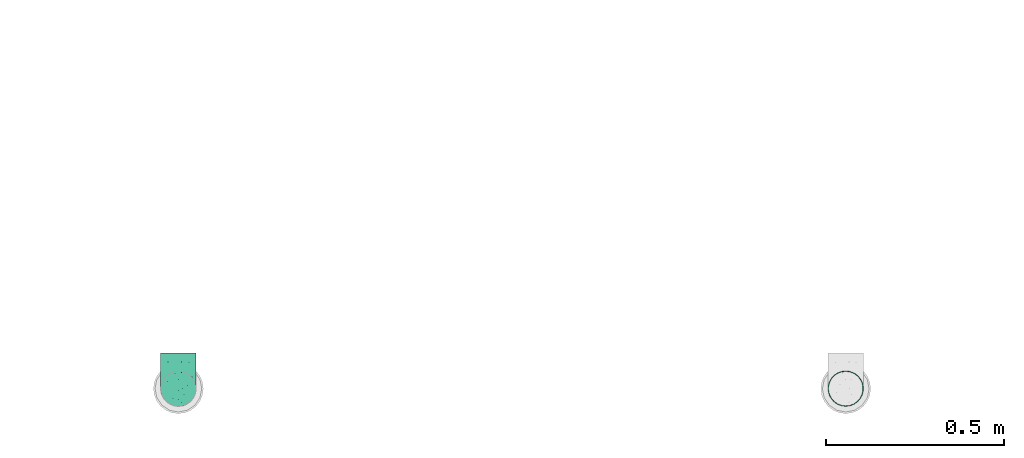
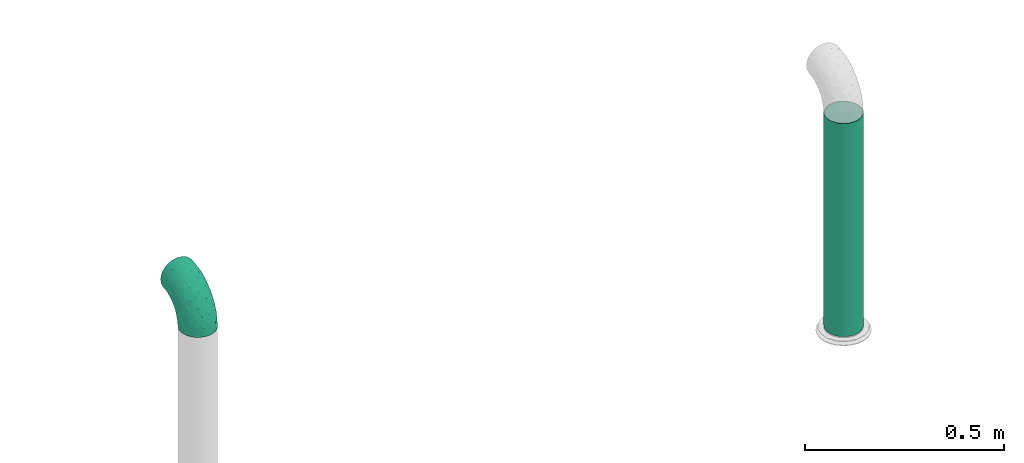
# One storey, part 56 of 103: 1 flow fitting, 1 flow segment.
"""IFC2X3 building model written with IfcOpenShell, lengths in millimetres."""

from ifc_helpers import new_model, entity, si_unit, converted_unit, derived_unit, direction, frame, origin_with_axes, origin_2d_with_axis, place, context, subcontext, project, spatial, hollow_circle, extrude, open_shell, surface_model, source, transform, mapped, material, layer, layer_set, layer_usage, type_object, element, save


model = new_model("IFC2X3")

# Units and contexts
model_context = context("Model", 3, precision=1e-05, world=origin_with_axes(), true_north=direction((0.0, 1.0)))
body_context = subcontext(model_context, "Body", "Model", "MODEL_VIEW")
ifc_project = project(units=[si_unit("AREAUNIT", "SQUARE_METRE"), si_unit("VOLUMEUNIT", "CUBIC_METRE", prefix="DECI"), si_unit("TIMEUNIT", "SECOND"), si_unit("THERMODYNAMICTEMPERATUREUNIT", "DEGREE_CELSIUS"), si_unit("PRESSUREUNIT", "PASCAL"), si_unit("MASSUNIT", "GRAM", prefix="KILO"), si_unit("LENGTHUNIT", "METRE", prefix="MILLI"), si_unit("POWERUNIT", "WATT"), si_unit("ELECTRICCURRENTUNIT", "AMPERE"), si_unit("ELECTRICVOLTAGEUNIT", "VOLT"), derived_unit("VOLUMETRICFLOWRATEUNIT", [(si_unit("VOLUMEUNIT", "CUBIC_METRE", prefix="DECI"), 1), (si_unit("TIMEUNIT", "SECOND"), -1)]), derived_unit("LINEARVELOCITYUNIT", [(si_unit("LENGTHUNIT", "METRE"), 1), (si_unit("TIMEUNIT", "SECOND"), -1)]), derived_unit("MASSDENSITYUNIT", [(si_unit("MASSUNIT", "GRAM", prefix="KILO"), 1), (si_unit("VOLUMEUNIT", "CUBIC_METRE"), -1)]), converted_unit("PLANEANGLEUNIT", "DEGREE", entity("IfcRatioMeasure", 0.01745), si_unit("PLANEANGLEUNIT", "RADIAN"), dimensions=[0, 0, 0, 0, 0, 0, 0])], contexts=[model_context])

# Site, building, storey
site_placement = place(None, origin_with_axes())
site = spatial("IfcSite", under=ifc_project, at=site_placement, CompositionType="ELEMENT")
building_placement = place(site_placement, origin_with_axes())
building = spatial("IfcBuilding", under=site, at=building_placement, Name="mc-building", CompositionType="ELEMENT")
storey_placement = place(building_placement, frame((0.0, 0.0, 5900.0), z_axis=(0.0, 0.0, 1.0), x_axis=(1.0, 0.0, 0.0)))
storey = spatial("IfcBuildingStorey", under=building, at=storey_placement, Name="3. Korrus", CompositionType="ELEMENT", Elevation=5900.0)

# Flow segment
ifc_material = material(Name="FZ1")
ifc_layer = layer(ifc_material, 0.0)
ifc_layer_set = layer_set([ifc_layer], Name="FZ1")
ifc_layer_usage = layer_usage(ifc_layer_set, "AXIS1", "POSITIVE", 0.0)
duct_segment_type = type_object("IfcDuctSegmentType", Name="Safe", PredefinedType="RIGIDSEGMENT")
shared_shape_1 = source(origin_with_axes(), body_context, "Body", "SweptSolid", [
    extrude(hollow_circle(Radius=50.0, WallThickness=2.0, at=origin_2d_with_axis()), frame((0.0, 0.0, 0.0), z_axis=(1.0, 0.0, 0.0), x_axis=(0.0, 1.0, 0.0)), (0.0, 0.0, 1.0), 653.0),
])
flow_segment_placement = place(storey_placement, frame((27561.56962, 573.88887, 2461.97044), z_axis=(1.0, 0.0, 0.0), x_axis=(0.0, 0.0, 1.0)))
element("IfcFlowSegment", 1, at=flow_segment_placement, inside=storey, type_object=duct_segment_type, material=ifc_layer_usage, Name="Safe", context=body_context, shape_type="MappedRepresentation", body=[
    mapped(shared_shape_1, transform((0.0, 0.0, 0.0), scale=1.0)),
])

# Flow fitting
duct_fitting_type = type_object("IfcDuctFittingType", Name="BU", PredefinedType="BEND")
shared_shape_2 = source(origin_with_axes(), body_context, "Body", "SurfaceModel", [
    surface_model("IfcShellBasedSurfaceModel", [(-100.0, -48.29629, -12.94095), (-100.0, -50.0, 0.0), (-100.0, -43.30127, -25.0), (-100.0, 48.29629, -12.94095), (-100.0, 43.30127, -25.0), (-100.0, 48.29629, 12.94095), (-100.0, -12.94095, -48.29629), (-100.0, 0.0, -50.0), (-100.0, -25.0, -43.30127), (-100.0, -35.35534, -35.35534), (-100.0, 35.35534, -35.35534), (-100.0, 25.0, -43.30127), (-100.0, 12.94095, -48.29629), (-100.0, 50.0, 0.0), (-100.0, -48.29629, 12.94095), (-100.0, -43.30127, 25.0), (-100.0, -35.35534, 35.35534), (-100.0, 0.0, 50.0), (-100.0, -25.0, 43.30127), (-100.0, -12.94095, 48.29629), (-100.0, 43.30127, 25.0), (-100.0, 35.35534, 35.35534), (-100.0, 25.0, 43.30127), (-100.0, 12.94095, 48.29629), (0.0, -100.0, -50.0), (12.94095, -100.0, -48.29629), (-12.94095, -100.0, -48.29629), (-48.29629, -100.0, 12.94095), (-25.0, -100.0, -43.30127), (-43.30127, -100.0, -25.0), (-35.35534, -100.0, -35.35534), (50.0, -100.0, 0.0), (48.29629, -100.0, 12.94095), (35.35534, -100.0, -35.35534), (25.0, -100.0, -43.30127), (48.29629, -100.0, -12.94095), (43.30127, -100.0, -25.0), (-48.29629, -100.0, -12.94095), (-43.30127, -100.0, 25.0), (-35.35534, -100.0, 35.35534), (12.94095, -100.0, 48.29629), (-25.0, -100.0, 43.30127), (-12.94095, -100.0, 48.29629), (43.30127, -100.0, 25.0), (35.35534, -100.0, 35.35534), (25.0, -100.0, 43.30127), (0.0, -100.0, 50.0), (-50.0, -100.0, 0.0), (-54.95374, -29.60867, 47.22379), (-69.67318, -34.70921, 41.41807), (-58.37939, -44.26324, 39.66767), (-81.95957, -10.85813, 49.17398), (-69.0983, -4.89435, 50.0), (-63.80701, -16.86512, 49.12211), (-71.45436, -24.34004, 46.19398), (-84.79657, -41.61468, 30.43807), (-68.68567, -49.28345, 29.46598), (-87.38486, -20.12422, 46.19398), (-29.12893, -54.21835, 47.49497), (-16.69326, -64.07661, 49.13167), (-19.0983, -41.22148, 50.0), (-57.82431, -60.07162, 27.24983), (-67.87621, -57.34916, 18.11021), (-58.07867, -67.98053, 16.35576), (-84.64671, -51.44953, 9.54872), (-90.54273, -47.92896, 16.84479), (-89.28706, -52.13093, 0.0), (-48.57141, -84.18266, 19.13417), (-80.49866, -49.85236, 19.13417), (-4.89435, -69.0983, 50.0), (-10.78328, -82.03604, 49.18466), (-51.49654, -84.66157, 9.29171), (-52.13093, -89.28706, 0.0), (-40.55308, -40.55308, 47.39468), (-41.22148, -19.0983, 50.0), (-84.25895, -32.24248, 39.66767), (-20.22969, -86.73423, 46.19398), (-24.76101, -70.36257, 46.19398), (-39.73574, -63.26064, 40.42863), (-32.70712, -82.37816, 39.66767), (-53.34351, -76.64659, 14.58596), (-52.07527, -72.10209, 22.70672), (-75.39343, -54.87419, 11.74349), (-45.34852, -49.56196, 42.93091), (-67.79776, -60.76145, 8.68857), (-41.23466, -86.33892, 30.43807), (-53.80602, -80.86583, 0.0), (-46.83364, -71.48109, 30.43807), (-59.22534, -72.75524, 0.0), (-51.32111, -56.42251, 36.03223), (-80.86583, -53.80602, 0.0), (-72.75524, -59.22534, 0.0), (-64.64466, -64.64466, 0.0), (-86.30081, -41.24353, -30.43807), (-84.6487, -51.45583, -9.51467), (-90.59087, -47.99544, -16.6365), (-72.72667, -42.3343, -34.47953), (-82.00387, -32.80624, -39.66767), (-41.22148, -19.0983, -50.0), (-66.13967, -17.89682, -48.73206), (-69.0983, -4.89435, -50.0), (-19.0983, -41.22148, -50.0), (-4.89435, -69.0983, -50.0), (-19.92688, -59.20071, -48.9627), (-32.19887, -84.44786, -39.66767), (-82.82099, -10.02515, -49.28938), (-41.61468, -84.79657, -30.43807), (-82.27704, -21.1002, -46.19398), (-64.48049, -30.28903, -45.01594), (-71.3903, -57.59661, -10.6727), (-22.65007, -76.4146, -46.19398), (-80.71765, -49.76775, -19.13417), (-57.71875, -61.44646, -25.88117), (-66.69474, -56.78794, -20.8562), (-63.27201, -52.13514, -30.43807), (-51.44953, -84.64671, -9.54872), (-49.18799, -68.95983, -29.38061), (-49.85236, -80.49866, -19.13417), (-52.50869, -28.2692, -48.00802), (-47.92896, -90.54273, -16.84479), (-11.48103, -81.33005, -49.0827), (-31.33477, -60.4193, -45.4939), (-39.98518, -39.98518, -47.65708), (-59.80479, -65.98498, -16.07996), (-52.24546, -47.26788, -40.83149), (-63.94971, -39.6845, -40.19955), (-55.20497, -74.81068, -11.71424), (-38.49923, -67.49589, -39.66767), (-52.04722, -57.72873, -34.6201), (-73.59404, -48.69992, -26.65479), (-47.57173, -4.1387, -49.13473), (13.59601, -32.77977, -38.42312), (13.52969, -19.02651, -30.72245), (29.5722, -42.84907, -27.71428), (17.59627, -59.41659, -43.64098), (27.49134, -63.71843, -37.951), (-25.90272, 27.798, -14.9099), (-42.84907, 29.5722, -27.71428), (-63.95523, 42.22253, -17.81382), (-20.45037, -20.45037, -48.41225), (-4.1387, -47.57173, -49.13473), (-68.61243, 10.20497, -47.82471), (-73.92917, 46.87327, -9.07697), (-63.71843, 27.49134, -37.951), (-73.47057, 38.0442, -29.22414), (-8.32573, 9.86545, -25.36336), (-32.77977, 13.59601, -38.42312), (-59.41659, 17.59627, -43.64098), (3.58524, -39.93936, -45.93923), (10.20497, -68.61244, -47.82471), (-39.93936, 3.58524, -45.93923), (-12.17948, -12.17948, -43.75507), (45.64165, -67.74269, -9.06645), (38.05536, -43.47505, -9.02401), (44.88888, -61.17714, 0.0), (17.21028, -10.65055, -15.96581), (-1.12135, 11.13977, -11.07369), (-25.0, 29.90381, 0.0), (38.0442, -73.47057, -29.22414), (42.22253, -63.95523, -17.81382), (32.46004, -37.55825, -18.52941), (6.06602, 6.06602, 0.0), (29.90381, -25.0, 0.0), (-45.78423, 39.05041, -8.65056), (-61.17714, 44.88888, 0.0), (-4.97501, -4.97501, -36.29915), (-63.95523, 42.22253, 17.81382), (-67.74269, 45.64165, 9.06645), (-42.84907, 29.5722, 27.71428), (-37.55825, 32.46004, 18.52941), (-73.47057, 38.0442, 29.22414), (10.20497, -68.61244, 47.82471), (-4.1387, -47.57173, 49.13473), (-32.77977, 13.59601, 38.42312), (-59.41659, 17.59627, 43.64098), (-39.93936, 3.58524, 45.93923), (-63.71843, 27.49134, 37.951), (-10.65055, 17.21028, 15.96581), (11.13977, -1.12135, 11.07369), (27.798, -25.90272, 14.9099), (39.05041, -45.78423, 8.65056), (46.87327, -73.92917, 9.07697), (-47.57173, -4.1387, 49.13473), (-68.61243, 10.20497, 47.82471), (-12.17948, -12.17948, 43.75507), (-20.45037, -20.45037, 48.41225), (3.58524, -39.93936, 45.93923), (-19.02651, 13.52969, 30.72245), (9.86545, -8.32574, 25.36336), (-43.47505, 38.05536, 9.02401), (29.5722, -42.84907, 27.71428), (42.22253, -63.95523, 17.81382), (38.0442, -73.47057, 29.22414), (13.59601, -32.77977, 38.42312), (17.59627, -59.41659, 43.64098), (27.49134, -63.71843, 37.951), (-4.97501, -4.97501, 36.29915)], [open_shell([[[0, 1, 2]], [[3, 4, 5]], [[6, 1, 7]], [[8, 1, 6]], [[1, 9, 2]], [[8, 9, 1]], [[10, 7, 5]], [[7, 10, 11]], [[11, 12, 7]], [[10, 5, 4]], [[3, 5, 13]], [[7, 14, 15]], [[7, 15, 16]], [[17, 16, 18]], [[16, 17, 7]], [[17, 18, 19]], [[7, 20, 5]], [[21, 20, 7]], [[22, 21, 7]], [[23, 22, 7]], [[23, 7, 17]], [[7, 1, 14]], [[24, 25, 26]], [[26, 27, 28]], [[29, 30, 27]], [[27, 30, 28]], [[26, 31, 32]], [[33, 31, 34]], [[25, 34, 31]], [[35, 31, 36]], [[33, 36, 31]], [[31, 26, 25]], [[37, 29, 27]], [[38, 27, 26]], [[39, 38, 26]], [[40, 41, 26]], [[39, 26, 41]], [[42, 41, 40]], [[32, 43, 26]], [[26, 43, 44]], [[26, 44, 45]], [[40, 26, 45]], [[40, 46, 42]], [[47, 37, 27]], [[48, 49, 50]], [[51, 52, 17]], [[48, 53, 54]], [[49, 55, 56]], [[16, 15, 55]], [[18, 57, 19]], [[58, 59, 60]], [[61, 62, 63]], [[64, 65, 14]], [[53, 51, 54]], [[66, 64, 14]], [[27, 38, 67]], [[65, 68, 55]], [[68, 65, 64]], [[69, 59, 70]], [[71, 72, 27]], [[73, 60, 74]], [[55, 49, 75]], [[42, 70, 76]], [[51, 57, 54]], [[77, 78, 79]], [[42, 76, 41]], [[46, 70, 42]], [[55, 68, 56]], [[75, 18, 16]], [[77, 79, 76]], [[80, 67, 81]], [[68, 82, 62]], [[83, 78, 58]], [[82, 84, 62]], [[39, 79, 85]], [[71, 67, 80]], [[72, 71, 86]], [[67, 85, 87]], [[88, 80, 63]], [[39, 41, 79]], [[87, 79, 78]], [[55, 75, 16]], [[50, 89, 83]], [[38, 39, 85]], [[56, 68, 62]], [[61, 87, 89]], [[48, 50, 83]], [[18, 75, 57]], [[54, 75, 49]], [[38, 85, 67]], [[85, 79, 87]], [[56, 62, 61]], [[50, 56, 89]], [[87, 61, 81]], [[90, 64, 66]], [[14, 1, 66]], [[91, 92, 84]], [[82, 90, 91]], [[90, 82, 64]], [[62, 84, 63]], [[84, 82, 91]], [[64, 82, 68]], [[65, 15, 14]], [[15, 65, 55]], [[72, 47, 27]], [[86, 71, 80]], [[67, 71, 27]], [[88, 63, 92]], [[63, 80, 81]], [[63, 81, 61]], [[87, 81, 67]], [[41, 76, 79]], [[70, 59, 77]], [[76, 70, 77]], [[69, 70, 46]], [[77, 59, 58]], [[59, 69, 60]], [[77, 58, 78]], [[73, 58, 60]], [[19, 57, 51]], [[54, 57, 75]], [[19, 51, 17]], [[53, 52, 51]], [[53, 74, 52]], [[73, 74, 48]], [[53, 48, 74]], [[83, 73, 48]], [[73, 83, 58]], [[78, 83, 89]], [[78, 89, 87]], [[61, 89, 56]], [[54, 49, 48]], [[50, 49, 56]], [[88, 86, 80]], [[63, 84, 92]], [[93, 2, 9]], [[66, 94, 90]], [[95, 94, 0]], [[96, 93, 97]], [[98, 99, 100]], [[9, 8, 97]], [[101, 102, 103]], [[104, 28, 30]], [[7, 105, 6]], [[30, 106, 104]], [[107, 105, 99]], [[97, 107, 108]], [[94, 109, 90]], [[8, 6, 107]], [[94, 66, 0]], [[110, 26, 28]], [[94, 111, 109]], [[112, 113, 114]], [[72, 115, 37]], [[116, 106, 117]], [[98, 118, 99]], [[119, 115, 117]], [[115, 119, 37]], [[110, 120, 26]], [[103, 110, 121]], [[117, 106, 119]], [[120, 110, 103]], [[98, 101, 122]], [[117, 123, 116]], [[108, 124, 125]], [[126, 117, 115]], [[30, 29, 106]], [[120, 102, 24]], [[110, 104, 127]], [[97, 125, 96]], [[118, 122, 124]], [[124, 127, 128]], [[93, 9, 97]], [[86, 126, 115]], [[127, 106, 116]], [[129, 113, 111]], [[2, 93, 95]], [[114, 129, 96]], [[28, 104, 110]], [[127, 104, 106]], [[8, 107, 97]], [[108, 107, 99]], [[118, 108, 99]], [[100, 99, 105]], [[128, 112, 114]], [[127, 124, 121]], [[66, 1, 0]], [[91, 90, 109]], [[95, 111, 94]], [[109, 123, 92]], [[114, 113, 129]], [[111, 95, 93]], [[95, 0, 2]], [[86, 115, 72]], [[37, 47, 72]], [[88, 92, 123]], [[123, 117, 126]], [[126, 88, 123]], [[88, 126, 86]], [[119, 29, 37]], [[29, 119, 106]], [[111, 93, 129]], [[124, 114, 125]], [[100, 105, 7]], [[6, 105, 107]], [[108, 118, 124]], [[122, 118, 98]], [[96, 129, 93]], [[109, 111, 113]], [[113, 123, 109]], [[116, 123, 112]], [[113, 112, 123]], [[116, 112, 128]], [[116, 128, 127]], [[124, 128, 114]], [[103, 122, 101]], [[127, 121, 110]], [[121, 122, 103]], [[122, 121, 124]], [[26, 120, 24]], [[102, 120, 103]], [[108, 125, 97]], [[109, 92, 91]], [[96, 125, 114]], [[100, 130, 98]], [[131, 132, 133]], [[134, 135, 34]], [[136, 137, 138]], [[101, 139, 140]], [[7, 141, 100]], [[138, 3, 142]], [[137, 143, 144]], [[142, 3, 13]], [[145, 146, 137]], [[146, 147, 143]], [[4, 138, 144]], [[3, 138, 4]], [[4, 144, 10]], [[140, 148, 149]], [[143, 11, 10]], [[147, 12, 11]], [[100, 141, 130]], [[98, 139, 101]], [[148, 134, 149]], [[139, 150, 151]], [[152, 153, 154]], [[150, 139, 130]], [[25, 24, 149]], [[141, 12, 147]], [[132, 145, 155]], [[156, 136, 157]], [[158, 33, 135]], [[148, 139, 151]], [[36, 33, 158]], [[34, 135, 33]], [[159, 160, 153]], [[160, 159, 133]], [[137, 146, 143]], [[152, 154, 31]], [[137, 136, 145]], [[161, 162, 155]], [[133, 159, 158]], [[134, 148, 131]], [[163, 164, 157]], [[163, 142, 164]], [[102, 101, 140]], [[162, 154, 153]], [[159, 35, 36]], [[155, 156, 161]], [[131, 165, 132]], [[155, 145, 156]], [[98, 130, 139]], [[150, 130, 141]], [[147, 150, 141]], [[7, 12, 141]], [[149, 24, 102]], [[148, 140, 139]], [[140, 149, 102]], [[34, 25, 134]], [[146, 151, 150]], [[143, 147, 11]], [[147, 146, 150]], [[145, 165, 146]], [[25, 149, 134]], [[135, 134, 131]], [[135, 131, 133]], [[151, 165, 131]], [[148, 151, 131]], [[165, 151, 146]], [[160, 133, 132]], [[132, 165, 145]], [[36, 158, 159]], [[133, 158, 135]], [[10, 144, 143]], [[137, 144, 138]], [[162, 153, 155]], [[159, 153, 152]], [[160, 155, 153]], [[155, 160, 132]], [[152, 35, 159]], [[35, 152, 31]], [[136, 138, 163]], [[164, 142, 13]], [[142, 163, 138]], [[136, 163, 157]], [[161, 156, 157]], [[136, 156, 145]], [[166, 5, 20]], [[167, 164, 13]], [[166, 168, 169]], [[170, 168, 166]], [[69, 171, 172]], [[173, 174, 175]], [[174, 176, 22]], [[161, 157, 177]], [[170, 21, 176]], [[20, 21, 170]], [[178, 179, 162]], [[180, 181, 154]], [[182, 175, 183]], [[183, 23, 17]], [[184, 185, 186]], [[74, 185, 182]], [[52, 74, 182]], [[187, 188, 177]], [[166, 169, 189]], [[190, 179, 188]], [[22, 176, 21]], [[180, 154, 162]], [[32, 191, 43]], [[192, 44, 43]], [[43, 191, 192]], [[32, 31, 181]], [[193, 194, 195]], [[194, 40, 45]], [[190, 193, 195]], [[45, 44, 195]], [[69, 46, 171]], [[74, 60, 185]], [[157, 164, 189]], [[167, 189, 164]], [[172, 60, 69]], [[185, 172, 186]], [[173, 187, 168]], [[191, 32, 181]], [[190, 195, 192]], [[179, 190, 191]], [[175, 174, 183]], [[171, 40, 194]], [[188, 193, 190]], [[175, 185, 184]], [[177, 178, 161]], [[173, 196, 187]], [[177, 188, 178]], [[60, 172, 185]], [[186, 172, 171]], [[194, 186, 171]], [[46, 40, 171]], [[183, 17, 52]], [[175, 182, 185]], [[182, 183, 52]], [[22, 23, 174]], [[193, 184, 186]], [[195, 194, 45]], [[194, 193, 186]], [[188, 196, 193]], [[23, 183, 174]], [[176, 174, 173]], [[176, 173, 168]], [[184, 196, 173]], [[175, 184, 173]], [[196, 184, 193]], [[169, 168, 187]], [[187, 196, 188]], [[20, 170, 166]], [[168, 170, 176]], [[44, 192, 195]], [[190, 192, 191]], [[157, 189, 177]], [[166, 189, 167]], [[169, 177, 189]], [[177, 169, 187]], [[167, 5, 166]], [[5, 167, 13]], [[179, 191, 180]], [[154, 181, 31]], [[181, 180, 191]], [[179, 180, 162]], [[161, 178, 162]], [[179, 178, 188]]])]),
])
flow_fitting_placement = place(storey_placement, frame((25689.63788, 573.88887, 3215.0), z_axis=(1.0, 0.0, 0.0), x_axis=(0.0, 0.0, 1.0)))
element("IfcFlowFitting", 2, at=flow_fitting_placement, inside=storey, type_object=duct_fitting_type, Name="BU", context=body_context, shape_type="MappedRepresentation", body=[
    mapped(shared_shape_2, transform((0.0, 0.0, 0.0), scale=1.0)),
])

save(model, "model.ifc")
